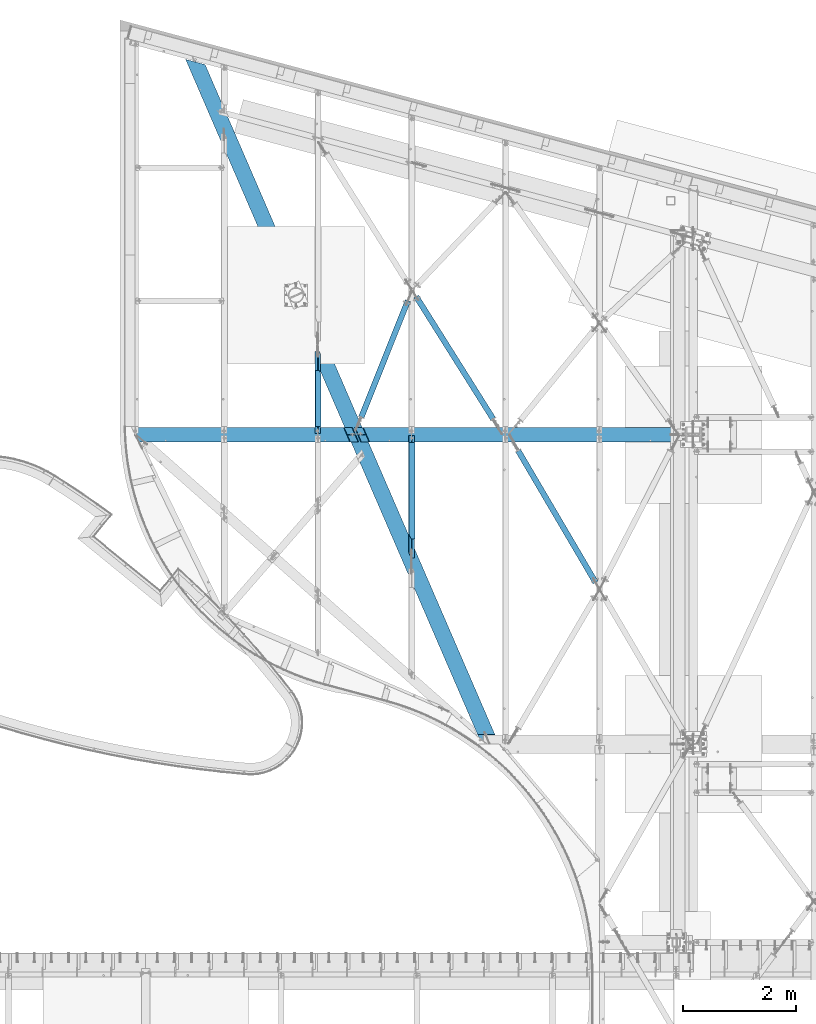
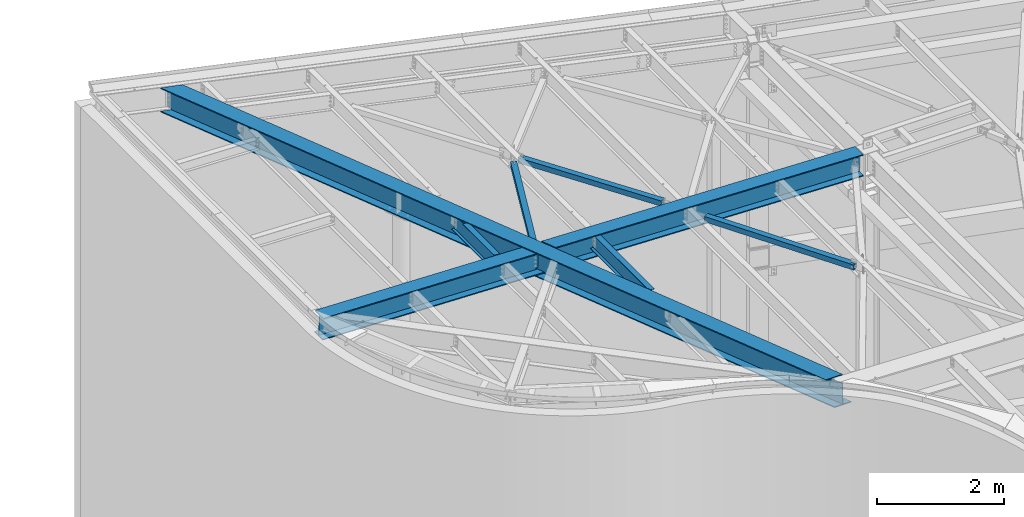
# One storey, part 1155 of 1763: 8 beams, 8 elements without a shape of their own.
"""IFC2X3 building model written with IfcOpenShell, lengths in millimetres."""

import ifcopenshell
import ifcopenshell.guid

model = None  # the IFC model being written
_history = None  # IfcOwnerHistory: only IFC2X3 demands one
_inside = {}  # id of a spatial element -> (the spatial element, [elements in it])
_under = {}  # id of a project, library or spatial element -> (it, [spatial elements below it])
_declared = {}  # id of a project -> (the project, [libraries it declares])
_typed = {}  # id of a type object -> (the type object, [elements of that type])
_made_of = {}  # id of a material, layer set ... -> (it, [elements and type objects made of it])


def new_model(schema):
    """Start an empty IFC model of exactly this schema.

    Asked for "IFC4X3", IfcOpenShell would pick the latest addendum, in which some entities
    have other attributes; the version numbers below select the first issue.
    IFC2X3 requires an IfcOwnerHistory on every rooted entity: one is made here for all.
    """
    global model, _history
    if schema == "IFC4X3":
        model = ifcopenshell.file(schema_version=(4, 3, 0, 0))
    else:
        model = ifcopenshell.file(schema=schema)
    _inside.clear()
    _under.clear()
    _declared.clear()
    _typed.clear()
    _made_of.clear()
    _history = None
    if model.schema == "IFC2X3":
        org = make("IfcOrganization", Name="unknown")
        user = make(
            "IfcPersonAndOrganization",
            ThePerson=make("IfcPerson", FamilyName="unknown"),
            TheOrganization=org,
        )
        app = make(
            "IfcApplication",
            ApplicationDeveloper=org,
            Version="unknown",
            ApplicationFullName="unknown",
            ApplicationIdentifier="unknown",
        )
        _history = make(
            "IfcOwnerHistory",
            OwningUser=user,
            OwningApplication=app,
            ChangeAction="ADDED",
            CreationDate=0,
        )
    return model


def make(cls, **values):
    """One entity of the class cls with the attributes given. An attribute that is None is left unset."""
    return model.create_entity(
        cls, **{name: value for name, value in values.items() if value is not None}
    )


def rooted(cls, **values):
    """An entity with a GlobalId (a new one), such as an element, a storey or a relation."""
    return make(cls, GlobalId=ifcopenshell.guid.new(), OwnerHistory=_history, **values)


def si_unit(unit_type, name, prefix=None):
    """IfcSIUnit, for example si_unit("LENGTHUNIT", "METRE", prefix="MILLI")."""
    return make("IfcSIUnit", UnitType=unit_type, Prefix=prefix, Name=name)


def assignment(units):
    """IfcUnitAssignment: the units of a project."""
    return None if units is None else make("IfcUnitAssignment", Units=units)


def point(xyz):
    """IfcCartesianPoint."""
    return None if xyz is None else make("IfcCartesianPoint", Coordinates=xyz)


def direction(xyz):
    """IfcDirection."""
    return None if xyz is None else make("IfcDirection", DirectionRatios=xyz)


def frame(location, z_axis=None, x_axis=None):
    """IfcAxis2Placement3D, a coordinate frame: its origin and axes. An axis left out is left unset."""
    return make(
        "IfcAxis2Placement3D",
        Location=point(location),
        Axis=direction(z_axis),
        RefDirection=direction(x_axis),
    )


def origin_with_axes():
    """The frame at (0, 0, 0) with the z axis (0, 0, 1) and the x axis (1, 0, 0) written out."""
    return frame((0.0, 0.0, 0.0), z_axis=(0.0, 0.0, 1.0), x_axis=(1.0, 0.0, 0.0))


def place(relative_to, where):
    """IfcLocalPlacement: puts the frame where relative to a parent placement (None: the world)."""
    return make(
        "IfcLocalPlacement", PlacementRelTo=relative_to, RelativePlacement=where
    )


def context(
    kind, dimensions, precision=None, world=None, true_north=None, identifier=None
):
    """IfcGeometricRepresentationContext, for example the 3D "Model" context."""
    return make(
        "IfcGeometricRepresentationContext",
        ContextIdentifier=identifier,
        ContextType=kind,
        CoordinateSpaceDimension=dimensions,
        Precision=precision,
        WorldCoordinateSystem=world,
        TrueNorth=true_north,
    )


def subcontext(parent, identifier, kind, view, scale=None):
    """IfcGeometricRepresentationSubContext, for example "Body" below "Model"."""
    return make(
        "IfcGeometricRepresentationSubContext",
        ContextIdentifier=identifier,
        ContextType=kind,
        ParentContext=parent,
        TargetScale=scale,
        TargetView=view,
    )


def project(units=None, contexts=None):
    """IfcProject with its units and contexts."""
    return rooted(
        "IfcProject",
        Name="project",
        RepresentationContexts=contexts,
        UnitsInContext=assignment(units),
    )


def spatial(cls, under=None, at=None, **own):
    """A site, building, storey or space (cls), placed at a placement, below another one or the project."""
    s = rooted(cls, ObjectPlacement=at, **own)
    if under is not None:
        _under.setdefault(under.id(), (under, []))[1].append(s)
    return s


def faces_of(points, faces, orient=None, outer=None):
    """IfcFace entities. A face is a list of loops; a loop is a list of indices into points, from 0.

    orient and outer hold one flag for each loop. By default every Orientation is true, the
    first loop of a face is its IfcFaceOuterBound and the others are IfcFaceBound.
    """
    made = []
    for i, loops in enumerate(faces):
        bounds = []
        for j, loop in enumerate(loops):
            is_outer = j == 0 if outer is None else outer[i][j]
            bounds.append(
                make(
                    "IfcFaceOuterBound" if is_outer else "IfcFaceBound",
                    Bound=make("IfcPolyLoop", Polygon=[points[k] for k in loop]),
                    Orientation=True if orient is None else orient[i][j],
                )
            )
        made.append(make("IfcFace", Bounds=bounds))
    return made


def faceted_brep(points, faces, orient=None, outer=None, voids=None):
    """IfcFacetedBrep: a solid bounded by flat faces; with voids (closed shells), ...WithVoids."""
    shared = [point(p) for p in points]
    hull = make("IfcClosedShell", CfsFaces=faces_of(shared, faces, orient, outer))
    if voids is None:
        return make("IfcFacetedBrep", Outer=hull)
    return make(
        "IfcFacetedBrepWithVoids",
        Outer=hull,
        Voids=[
            make(cls, CfsFaces=faces_of(shared, fs, o, b)) for cls, fs, o, b in voids
        ],
    )


def shape(context_of_items, identifier, shape_type, items):
    """IfcShapeRepresentation: the items that make up one representation, for example the "Body"."""
    return make(
        "IfcShapeRepresentation",
        ContextOfItems=context_of_items,
        RepresentationIdentifier=identifier,
        RepresentationType=shape_type,
        Items=items,
    )


def material(Name=None, Category=None):
    """IfcMaterial."""
    return make("IfcMaterial", Name=Name, Category=Category)


def made_of(thing, what):
    """Note that an element or type object is made of a material, layer set ...; save() writes the relation."""
    if what is not None:
        _made_of.setdefault(what.id(), (what, []))[1].append(thing)
    return thing


def type_object(cls, material=None, **own):
    """A type object (cls), such as IfcWallType, which elements share."""
    return made_of(rooted(cls, **own), material)


def element(
    cls,
    number,
    at=None,
    inside=None,
    cuts=None,
    type_object=None,
    material=None,
    context=None,
    identifier="Body",
    shape_type=None,
    held_by="IfcProductDefinitionShape",
    body=None,
    shapes=None,
    **own,
):
    """One element of the class cls, such as IfcWall. Its Tag is "e" and its number.

    at: its placement. inside: the storey or other place that contains it. cuts: it is an
    opening in that element (IfcRelVoidsElement). A single representation is given by context,
    identifier, shape_type and body (its items); several are given by shapes. held_by: the class
    of the entity that holds the representations. save() writes the other relations.
    """
    e = rooted(cls, Tag="e%d" % number, ObjectPlacement=at, **own)
    if body is not None:
        shapes = [shape(context, identifier, shape_type, body)]
    if shapes is not None:
        e.Representation = make(held_by, Representations=shapes)
    if inside is not None:
        _inside.setdefault(inside.id(), (inside, []))[1].append(e)
    if cuts is not None:
        rooted(
            "IfcRelVoidsElement", RelatingBuildingElement=cuts, RelatedOpeningElement=e
        )
    if type_object is not None:
        _typed.setdefault(type_object.id(), (type_object, []))[1].append(e)
    return made_of(e, material)


def aggregate(whole, parts):
    """IfcRelAggregates: a whole, such as a stair, and the parts it consists of."""
    return rooted("IfcRelAggregates", RelatingObject=whole, RelatedObjects=parts)


def save(model, path):
    """Write the relations noted so far, then the file.

    IfcRelAggregates (storeys below a building ...), IfcRelContainedInSpatialStructure (elements
    in a storey), IfcRelDefinesByType, IfcRelAssociatesMaterial and IfcRelDeclares: one each for
    every whole, place, type object, material and project.
    """
    for whole, parts in _under.values():
        aggregate(whole, parts)
    for where, things in _inside.values():
        rooted(
            "IfcRelContainedInSpatialStructure",
            RelatedElements=things,
            RelatingStructure=where,
        )
    for kind, things in _typed.values():
        rooted("IfcRelDefinesByType", RelatedObjects=things, RelatingType=kind)
    for what, things in _made_of.values():
        rooted("IfcRelAssociatesMaterial", RelatedObjects=things, RelatingMaterial=what)
    for by, libraries in _declared.values():
        rooted("IfcRelDeclares", RelatingContext=by, RelatedDefinitions=libraries)
    model.write(path)


model = new_model("IFC2X3")

# Units and contexts
model_context = context("Model", 3, precision=1e-05, world=origin_with_axes())
body_context = subcontext(model_context, "Body", "Model", "MODEL_VIEW")
ifc_project = project(units=[si_unit("LENGTHUNIT", "METRE", prefix="MILLI"), si_unit("AREAUNIT", "SQUARE_METRE"), si_unit("VOLUMEUNIT", "CUBIC_METRE"), si_unit("MASSUNIT", "GRAM", prefix="KILO"), si_unit("TIMEUNIT", "SECOND"), si_unit("PLANEANGLEUNIT", "RADIAN"), si_unit("SOLIDANGLEUNIT", "STERADIAN"), si_unit("THERMODYNAMICTEMPERATUREUNIT", "DEGREE_CELSIUS"), si_unit("LUMINOUSINTENSITYUNIT", "LUMEN")], contexts=[model_context])

# Site, building, storey
site_placement = place(None, origin_with_axes())
site = spatial("IfcSite", under=ifc_project, at=site_placement, CompositionType="ELEMENT")
building_placement = place(site_placement, origin_with_axes())
building = spatial("IfcBuilding", under=site, at=building_placement, Name="Undefined", CompositionType="ELEMENT")
storey_placement = place(building_placement, origin_with_axes())
storey = spatial("IfcBuildingStorey", under=building, at=storey_placement, Name="Undefined", CompositionType="ELEMENT", Elevation=0.0)

# Assembly, beam
assembly_1_placement = place(storey_placement, origin_with_axes())
assembly_1 = element("IfcElementAssembly", 1, at=assembly_1_placement, inside=storey, Name="H. BRACE", AssemblyPlace="NOTDEFINED", PredefinedType="RIGID_FRAME")
ifc_material_1 = material()
beam_type_1 = type_object("IfcBeamType", Name="HSS4X4X3/8", PredefinedType="NOTDEFINED")
beam_1_placement = place(assembly_1_placement, frame((-41338.5382217807, 60452.3469434345, 12371.3875), z_axis=(0.0, 0.0, 1.0), x_axis=(-0.50652204411247, 0.862227011191441, 0.0)))
beam_1 = element("IfcBeam", 2, at=beam_1_placement, type_object=beam_type_1, material=ifc_material_1, Name="H. BRACE", ObjectType="HSS4X4X3/8", context=body_context, shape_type="Brep", body=[
    faceted_brep([(142.888415242414, 6.34999999947649, 50.7999999999993), (142.888415242414, 6.34999999947649, 41.2749999999996), (227.099700886218, 6.34999999945467, 41.2749999999996), (227.099700886218, 6.34999999945467, 50.7999999999938), (227.099700886218, -6.35000000040782, 50.7999999999938), (227.099700886218, -6.35000000040782, 41.2749999999996), (142.888415242414, -6.35000000037144, 41.2749999999996), (142.888415242414, -6.35000000037144, 50.7999999999993), (142.888415242414, 6.34999999947649, -41.2749999999996), (142.888415242414, 6.34999999947649, -50.7999999999993), (227.099700886218, 6.34999999945467, -50.8000000000047), (227.099700886218, 6.34999999945467, -41.2749999999996), (227.099700886218, -6.35000000040782, -41.2749999999996), (227.099700886218, -6.35000000040782, -50.8000000000047), (142.888415242414, -6.35000000037144, -50.7999999999993), (142.888415242414, -6.35000000037144, -41.2749999999996), (142.888415242414, -41.2749999998869, -41.2749999999996), (142.888415242414, -41.2749999998869, 41.2749999999996), (2854.96770806139, -41.2750000008291, 41.2749999999996), (2854.9677080754, -41.2750000008291, -41.2749999999996), (142.888415242414, 50.7999999997573, -50.7999999999993), (2854.96770804827, 50.7999999988115, -50.7999999999993), (2854.96770808, -50.8000000007978, -50.7999999999993), (142.888415242414, -50.7999999998519, -50.7999999999993), (142.888415242414, -50.7999999998519, 50.7999999999993), (2854.96770806274, -50.8000000007942, 50.7999999999993), (142.888415242414, 41.2749999997959, 41.2749999999996), (2854.96770803559, 41.27499999885, 41.2749999999996), (142.888415242414, 41.2749999997959, -41.2749999999996), (2854.96770804962, 41.2749999988428, -41.2749999999996), (2854.96770803099, 50.7999999988078, 50.7999999999993), (142.888415242414, 50.7999999997573, 50.7999999999993)], [[[0, 1, 2, 3]], [[4, 5, 6, 7]], [[3, 2, 5, 4]], [[8, 9, 10, 11]], [[12, 13, 14, 15]], [[11, 10, 13, 12]], [[16, 17, 18, 19]], [[9, 20, 21, 22, 23, 14, 13, 10]], [[24, 23, 22, 25]], [[17, 16, 15, 14, 23, 24, 7, 6]], [[1, 26, 27, 18, 17, 6, 5, 2]], [[26, 28, 29, 27]], [[25, 22, 21, 30], [18, 27, 29, 19]], [[20, 31, 30, 21]], [[24, 25, 30, 31, 0, 3, 4, 7]], [[31, 20, 9, 8, 28, 26, 1, 0]], [[16, 19, 29, 28, 8, 11, 12, 15]]]),
])
aggregate(assembly_1, [beam_1])

assembly_2_placement = place(storey_placement, origin_with_axes())
assembly_2 = element("IfcElementAssembly", 3, at=assembly_2_placement, inside=storey, Name="H. BRACE", AssemblyPlace="NOTDEFINED", PredefinedType="RIGID_FRAME")
beam_2_placement = place(assembly_2_placement, frame((-45677.6148262171, 63248.1761413704, 12475.765625), z_axis=(0.0, 0.0, 1.0), x_axis=(0.371159417076474, 0.928569161191266, 0.0)))
beam_2 = element("IfcBeam", 4, at=beam_2_placement, type_object=beam_type_1, material=ifc_material_1, Name="H. BRACE", ObjectType="HSS4X4X3/8", context=body_context, shape_type="Brep", body=[
    faceted_brep([(2510.10293792247, 6.35000001345179, 50.7999999999993), (2425.96543793978, 6.3500000131753, 50.7999999999993), (2425.96543793978, 6.3500000131753, 41.2749999999996), (2510.10293792247, 6.35000001345179, 41.2749999999996), (2425.96543793981, -6.3499999869091, 50.7999999999993), (2425.96543793981, -6.3499999869091, 41.2749999999996), (2510.10293792246, -6.34999998734565, 50.7999999999993), (2510.10293792246, -6.34999998734565, 41.2749999999996), (2510.10293792247, 6.35000001345179, -41.2749999999996), (2425.96543793978, 6.3500000131753, -41.2749999999996), (2425.96543793978, 6.3500000131753, -50.7999999999993), (2510.10293792247, 6.35000001345179, -50.7999999999993), (2425.96543793981, -6.3499999869091, -41.2749999999996), (2425.96543793981, -6.3499999869091, -50.7999999999993), (2510.10293792246, -6.34999998734565, -41.2749999999996), (2510.10293792246, -6.34999998734565, -50.7999999999993), (285.37614554647, 41.2750000009983, 41.2749999999996), (285.376145584705, 41.2750000009983, -41.2749999999996), (2510.10293792247, 41.2750000079832, -41.2749999999996), (2510.10293792247, 41.2750000079832, 41.2749999999996), (2510.10293792247, -41.274999992238, 41.2749999999996), (285.376145562812, -41.2749999992229, 41.2749999999996), (285.376145601054, -41.2749999992229, -41.2749999999996), (2510.10293792247, -41.274999992238, -41.2749999999996), (285.376145607348, -50.7999999992462, -50.7999999999993), (285.376145560287, -50.7999999992462, 50.7999999999993), (285.376145540162, 50.8000000010215, 50.7999999999993), (285.376145587237, 50.8000000010215, -50.7999999999993), (2510.10293792247, 50.8000000080065, 50.7999999999993), (2510.10293792247, 50.8000000080065, -50.7999999999993), (2510.10293792246, -50.7999999922613, -50.7999999999993), (2510.10293792246, -50.7999999922613, 50.7999999999993)], [[[0, 1, 2, 3]], [[4, 5, 2, 1]], [[6, 7, 5, 4]], [[8, 9, 10, 11]], [[12, 13, 10, 9]], [[14, 15, 13, 12]], [[16, 17, 18, 19]], [[20, 21, 16, 19, 3, 2, 5, 7]], [[22, 21, 20, 23]], [[9, 8, 18, 17, 22, 23, 14, 12]], [[24, 25, 26, 27], [16, 21, 22, 17]], [[27, 26, 28, 29]], [[19, 18, 8, 11, 29, 28, 0, 3]], [[30, 24, 27, 29, 11, 10, 13, 15]], [[25, 24, 30, 31]], [[1, 0, 28, 26, 25, 31, 6, 4]], [[31, 30, 15, 14, 23, 20, 7, 6]]]),
])
aggregate(assembly_2, [beam_2])

assembly_3_placement = place(storey_placement, origin_with_axes())
assembly_3 = element("IfcElementAssembly", 5, at=assembly_3_placement, inside=storey, Name="H. BRACE", AssemblyPlace="NOTDEFINED", PredefinedType="RIGID_FRAME")
beam_3_placement = place(assembly_3_placement, frame((-43055.1791956861, 63201.5499998402, 12475.765625), z_axis=(0.0, 0.0, 1.0), x_axis=(-0.532535588045035, 0.84640761307158, 0.0)))
beam_3 = element("IfcBeam", 6, at=beam_3_placement, type_object=beam_type_1, material=ifc_material_1, Name="H. BRACE", ObjectType="HSS4X4X3/8", context=body_context, shape_type="Brep", body=[
    faceted_brep([(2898.33890135751, 6.35000001674643, 50.7999999999993), (2820.76937611714, 6.35000001673916, 50.7999999999993), (2820.76937611714, 6.35000001673916, 41.2749999999996), (2898.33890135751, 6.35000001674643, 41.2749999999996), (2820.76937611714, -6.34999998325065, 50.7999999999993), (2820.76937611714, -6.34999998325065, 41.2749999999996), (2898.33890135751, -6.34999998325793, 50.7999999999993), (2898.33890135751, -6.34999998325793, 41.2749999999996), (2898.33890135751, 6.35000001674643, -41.2749999999996), (2820.76937611714, 6.35000001673916, -41.2749999999996), (2820.76937611714, 6.35000001673916, -50.7999999999993), (2898.33890135751, 6.35000001674643, -50.7999999999993), (2820.76937611714, -6.34999998325065, -41.2749999999996), (2820.76937611714, -6.34999998325065, -50.7999999999993), (2898.33890135751, -6.34999998325793, -41.2749999999996), (2898.33890135751, -6.34999998325793, -50.7999999999993), (333.048359995955, 41.2749999999928, 41.2749999999996), (333.04836002292, 41.2749999999928, -41.2749999999996), (2898.33890135751, 41.2750000000001, -41.2749999999996), (2898.33890135751, 41.2750000000001, 41.2749999999996), (2898.33890135751, -41.274999999981, 41.2749999999996), (333.048360013418, -41.2749999999883, 41.2749999999996), (333.048360040368, -41.2749999999883, -41.2749999999996), (2898.33890135751, -41.274999999981, -41.2749999999996), (333.04836004549, -50.7999999999824, -50.7999999999993), (333.048360012312, -50.7999999999824, 50.7999999999993), (333.048359990818, 50.799999999987, 50.7999999999993), (333.048360024011, 50.799999999987, -50.7999999999993), (2898.33890135751, 50.8000000000015, 50.7999999999993), (2898.33890135751, 50.8000000000015, -50.7999999999993), (2898.33890135751, -50.7999999999824, -50.7999999999993), (2898.33890135751, -50.7999999999824, 50.7999999999993)], [[[0, 1, 2, 3]], [[4, 5, 2, 1]], [[6, 7, 5, 4]], [[8, 9, 10, 11]], [[12, 13, 10, 9]], [[14, 15, 13, 12]], [[16, 17, 18, 19]], [[20, 21, 16, 19, 3, 2, 5, 7]], [[22, 21, 20, 23]], [[9, 8, 18, 17, 22, 23, 14, 12]], [[24, 25, 26, 27], [16, 21, 22, 17]], [[27, 26, 28, 29]], [[19, 18, 8, 11, 29, 28, 0, 3]], [[30, 24, 27, 29, 11, 10, 13, 15]], [[25, 24, 30, 31]], [[1, 0, 28, 26, 25, 31, 6, 4]], [[31, 30, 15, 14, 23, 20, 7, 6]]]),
])
aggregate(assembly_3, [beam_3])

assembly_4_placement = place(storey_placement, origin_with_axes())
assembly_4 = element("IfcElementAssembly", 7, at=assembly_4_placement, inside=storey, Name="BEAM", AssemblyPlace="NOTDEFINED", PredefinedType="RIGID_FRAME")
ifc_material_2 = material(Name="STEEL/A992")
beam_type_2 = type_object("IfcBeamType", Name="W12X16", PredefinedType="NOTDEFINED")
beam_4_placement = place(assembly_4_placement, frame((-44674.7062632819, 60918.8918433085, 12440.7807458876), z_axis=(0.0294363099980619, 0.0, 0.999566657934176), x_axis=(0.0, 1.0, 0.0)))
beam_4 = element("IfcBeam", 8, at=beam_4_placement, type_object=beam_type_2, material=ifc_material_2, Name="BEAM", ObjectType="W12X16", context=body_context, shape_type="Brep", body=[
    faceted_brep([(419.267503132403, -3.17499999983556, 112.419608019094), (419.267503132403, 3.17500000017026, 112.232606414957), (92.0372966428404, 3.17500000017026, 112.232606414957), (92.0372966428404, -3.17499999983556, 112.419608019094), (424.12758265045, -3.17499999983556, 113.386757048042), (424.12758265045, 3.17500000017026, 113.199755443902), (428.247759118603, -3.17499999983556, 116.140964462451), (428.247759118603, 3.17500000017026, 115.953962858312), (431.000773019077, -3.17499999982101, 120.26292715043), (431.000773019077, 3.17500000017753, 120.075925546294), (431.967502941668, -3.17499999981374, 125.125113658423), (431.967502941668, 3.17500000018481, 124.938112054286), (431.967502941668, -50.7999999997846, 152.400000000001), (431.967502941668, 19.0582604178198, 152.40000000002), (431.967502941668, 18.8712588136696, 146.050000000019), (431.967502941668, 3.17500000022119, 146.050000000016), (431.967502941668, -3.17499999978463, 146.050000000014), (431.967502941668, -50.7999999997919, 146.050000000001), (186.143687162039, 50.7999999997701, -152.400000000005), (185.711491960239, 50.7999999997774, -146.050000000007), (2264.40190669086, 50.7999999997774, -146.050000000007), (2264.40190669086, 50.7999999997701, -152.400000000005), (2264.40190669086, -50.800000000243, -146.050000000032), (2264.40190669086, -3.17500000023574, -146.050000000021), (92.0372966428404, -3.17500000023574, -146.050000000021), (92.0372966428404, -50.800000000243, -146.050000000032), (2264.40190669086, -50.8000000002576, -152.400000000034), (92.0372966428404, -50.8000000002576, -152.400000000034), (92.0372965872593, 10.0821818504337, -152.400000000018), (92.0372965886854, 10.2691834513098, -146.050000000017), (2264.40190669086, 3.17499999977008, -146.050000000017), (92.0372966428404, 3.17499999977008, -146.050000000017), (2264.40190669086, 3.17500000017026, 114.040001668231), (2264.40190669086, -3.17499999982829, 114.040001668242), (2226.30190650009, 3.17500000017026, 114.040001668458), (2226.30190650009, -3.17499999982829, 114.040001668443), (2221.44182698205, 3.17500000017026, 114.835632793114), (2221.44182698205, -3.17499999982829, 114.835632793118), (2152.48316260406, 3.17500000017026, 114.835632793258), (2152.48316260406, -3.17499999982829, 114.835632793245), (2147.62308308601, 3.17500000017026, 115.802362715847), (2147.62308308601, -3.17499999982829, 115.802362715833), (2143.50290661786, 3.17500000017753, 118.555376616327), (2143.50290661786, -3.17499999982829, 118.555376616312), (2140.74989271739, 3.17500000018481, 122.67555308448), (2140.74989271739, -3.17499999981374, 122.675553084468), (2139.7831627948, 3.17500000019209, 127.535632602527), (2139.7831627948, -3.17499999980646, 127.535632602516), (2139.7831627948, 50.8000000002357, 152.400000000031), (2139.7831627948, 50.8000000002285, 146.050000000028), (505.760714963304, 50.8000000002285, 146.050000000028), (505.328519752664, 50.8000000002357, 152.400000000031), (2139.7831627948, -50.7999999997846, 152.400000000001), (2139.7831627948, -50.7999999997919, 146.050000000001), (2139.7831627948, -3.17499999978463, 146.050000000014), (2139.7831627948, 3.17500000022119, 146.050000000016)], [[[0, 1, 2, 3]], [[4, 5, 1, 0]], [[6, 7, 5, 4]], [[8, 9, 7, 6]], [[10, 11, 9, 8]], [[12, 13, 14, 15, 11, 10, 16, 17]], [[18, 19, 20, 21]], [[22, 23, 24, 25]], [[26, 22, 25, 27]], [[18, 21, 26, 27, 28]], [[19, 18, 28, 29]], [[30, 20, 19, 29, 31]], [[23, 22, 26, 21, 20, 30, 32, 33]], [[33, 32, 34, 35]], [[35, 34, 36, 37]], [[38, 39, 37, 36]], [[39, 38, 40, 41]], [[41, 40, 42, 43]], [[43, 42, 44, 45]], [[45, 44, 46, 47]], [[48, 49, 50, 51]], [[52, 53, 54, 47, 46, 55, 49, 48]], [[53, 52, 12, 17]], [[54, 53, 17, 16]], [[8, 6, 4, 0, 3, 24, 23, 33, 35, 37, 39, 41, 43, 45, 47, 54, 16, 10]], [[31, 29, 28, 27, 25, 24, 3, 2]], [[55, 46, 44, 42, 40, 38, 36, 34, 32, 30, 31, 2, 1, 5, 7, 9, 11, 15]], [[50, 49, 55, 15, 14]], [[51, 50, 14, 13]], [[52, 48, 51, 13, 12]]]),
])
aggregate(assembly_4, [beam_4])

assembly_5_placement = place(storey_placement, origin_with_axes())
assembly_5 = element("IfcElementAssembly", 9, at=assembly_5_placement, inside=storey, Name="BEAM", AssemblyPlace="NOTDEFINED", PredefinedType="RIGID_FRAME")
beam_5_placement = place(assembly_5_placement, frame((-46340.5472371989, 63201.55, 12489.8609543434), z_axis=(0.0294363099980619, 0.0, 0.999566657934176), x_axis=(0.0, 1.0, 0.0)))
beam_5 = element("IfcBeam", 10, at=beam_5_placement, type_object=beam_type_2, material=ifc_material_2, Name="BEAM", ObjectType="W12X16", context=body_context, shape_type="Brep", body=[
    faceted_brep([(18.2562499854539, 3.17499999977008, -146.050000000016), (18.2562499854539, 50.7999999997701, -146.050000000005), (18.2562499854539, 50.7999999997628, -152.400000000003), (18.2562499854539, -50.8000000002576, -152.400000000032), (18.2562499854539, -50.8000000002503, -146.050000000032), (18.2562499854539, -3.17500000024302, -146.050000000019), (18.2562499988926, -3.17499999983556, 107.996414197045), (18.2562499988926, 3.17500000015571, 107.996414197038), (130.175006293146, -3.17499999983556, 107.996414196812), (130.175006293146, 3.17500000016298, 107.996414196827), (135.035085811192, -3.17499999983556, 108.963144119401), (135.035085811192, 3.17500000016298, 108.963144119414), (139.155262279346, -3.17499999982829, 111.716158019881), (139.155262279346, 3.17500000017026, 111.716158019894), (141.90827617982, -3.17499999982101, 115.836334488036), (141.90827617982, 3.17500000017753, 115.836334488049), (142.875006102411, -3.17499999982101, 120.696414006083), (142.875006102411, 3.17500000018481, 120.696414006095), (142.874993882375, -50.7999999997919, 152.400000000001), (142.874993882375, 50.8000000002285, 152.400000000032), (142.874993882375, 50.8000000002212, 146.05000000003), (142.874993882375, 3.17500000022119, 146.050000000019), (142.874993882375, -3.17499999979191, 146.050000000014), (142.874993882375, -50.7999999997992, 146.050000000001), (1064.18048512434, -50.7999999997919, 146.050000000003), (1063.7482899137, -50.7999999997774, 152.400000000001), (1137.10930630327, 50.800000000243, 152.400000000031), (1137.10930630327, -19.058260599697, 152.400000000012), (1137.10930630327, 50.8000000002285, 146.05000000003), (1137.10930630327, 3.17500000022119, 146.050000000017), (1477.0395126021, 3.17499999977008, -146.050000000016), (1137.10930630327, 3.17500000017026, 117.426500764246), (1138.07603622586, 3.17500000017026, 112.564314256253), (1140.82905012633, 3.17500000016298, 108.442351568272), (1144.94922659449, 3.17500000015571, 105.688144153863), (1149.80930611253, 3.17500000014843, 104.720995124917), (1477.0395126021, 3.17500000014843, 104.720995124917), (1477.0395126021, 50.7999999997846, -146.050000000005), (1477.0395126021, 50.7999999997774, -152.400000000003), (1424.42386185303, -50.8000000002576, -152.400000000032), (1477.03951256677, -28.034335686847, -152.400000000027), (1423.99166665124, -50.8000000002357, -146.050000000032), (1477.03951256819, -27.8473340859782, -146.050000000025), (1477.0395126021, -3.17500000023574, -146.050000000021), (1144.94922659449, -3.17499999984284, 105.875145758), (1140.82905012633, -3.17499999983556, 108.629353172408), (1138.07603622586, -3.17499999982829, 112.751315860391), (1137.10930630327, -3.17499999982101, 117.613502368382), (1137.10930630327, -3.17499999978463, 146.050000000014), (1477.0395126021, -3.17499999984284, 104.907996729053), (1149.80930611253, -3.17499999984284, 104.907996729053), (1137.10930630327, -19.2452622038472, 146.05000000001)], [[[0, 1, 2, 3, 4, 5, 6, 7]], [[8, 9, 7, 6]], [[10, 11, 9, 8]], [[12, 13, 11, 10]], [[14, 15, 13, 12]], [[16, 17, 15, 14]], [[18, 19, 20, 21, 17, 16, 22, 23]], [[18, 23, 24, 25]], [[26, 19, 18, 25, 27]], [[20, 19, 26, 28]], [[21, 20, 28, 29]], [[30, 0, 7, 9, 11, 13, 15, 17, 21, 29, 31, 32, 33, 34, 35, 36]], [[1, 0, 30, 37]], [[2, 1, 37, 38]], [[39, 3, 2, 38, 40]], [[4, 3, 39, 41]], [[5, 4, 41, 42, 43]], [[44, 45, 46, 47, 48, 22, 16, 14, 12, 10, 8, 6, 5, 43, 49, 50]], [[23, 22, 48, 51, 24]], [[27, 25, 24, 51]], [[48, 47, 31, 29, 28, 26, 27, 51]], [[46, 32, 31, 47]], [[45, 33, 32, 46]], [[44, 34, 33, 45]], [[50, 35, 34, 44]], [[49, 36, 35, 50]], [[43, 42, 40, 38, 37, 30, 36, 49]], [[41, 39, 40, 42]]]),
])
aggregate(assembly_5, [beam_5])

assembly_6_placement = place(storey_placement, origin_with_axes())
assembly_6 = element("IfcElementAssembly", 11, at=assembly_6_placement, inside=storey, Name="BEAM", AssemblyPlace="NOTDEFINED", PredefinedType="RIGID_FRAME")
beam_type_3 = type_object("IfcBeamType", Name="W16X77", PredefinedType="NOTDEFINED")
beam_6_placement = place(assembly_6_placement, frame((-45663.5890366639, 63201.5500000137, 12420.9685247061), z_axis=(0.0307997289940758, 0.0, 0.999525575807789), x_axis=(0.999525575807789, 0.0, -0.0307997289940772)))
beam_6 = element("IfcBeam", 12, at=beam_6_placement, type_object=beam_type_3, material=ifc_material_2, Name="BEAM", ObjectType="W16X77", context=body_context, shape_type="Brep", body=[
    faceted_brep([(204.625998440351, -5.55625000000146, 152.143278683869), (199.817766600288, 5.55625000000146, 152.142870531523), (17.9196580551143, 5.55625000000146, 152.108225655904), (22.7278898925651, -5.55625000000146, 152.108633808275), (210.300759519785, -5.55625000000146, 153.693819866707), (205.492527679708, 5.55625000000146, 153.693411714363), (214.128280453129, -5.55625000000146, 157.839824109173), (209.320048613059, 5.55625000000146, 157.839415956829), (214.862809046055, -5.55625000000146, 163.231881709071), (210.054577205985, 5.55625000000146, 163.231473556723), (212.265276558675, -5.55625000000146, 168.115027062271), (207.457044718605, 5.55625000000146, 168.114618909925), (187.325439452565, -5.55625000000146, 190.241785832706), (182.517207612502, 5.55625000000146, 190.241377680362), (166.568662949197, -5.55625000000146, 190.240023874074), (161.760431109135, 5.55625000000146, 190.239615721728), (232.631830981736, -130.175000000003, 209.549999999846), (119.987842236485, 130.175000000003, 209.549999999901), (108.006195037597, 130.175000000003, 190.499999999913), (161.924201845541, 5.55625000000146, 190.499999999884), (166.732176974911, -5.55625000000146, 190.499999999884), (220.650183782855, -130.175000000003, 190.499999999856), (22.729258539126, -5.55625000000146, 135.985316982933), (17.9210267016824, 5.55625000000146, 135.984908747272), (26.8172090465087, 5.55625000000146, -152.717248164201), (31.6254408865716, -5.55625000000146, -152.716840011857), (66.6260876020824, 5.55625000000146, -152.668447349335), (71.4343194421454, -5.55625000000146, -152.668039196991), (72.4959835151967, 5.55625000000146, -154.337718851591), (77.3042153552597, -5.55625000000146, -154.337310699248), (76.3081416135974, 5.55625000000146, -158.761251037276), (81.1163734536603, -5.55625000000146, -158.760842884931), (76.7260013838459, 5.55625000000146, -164.388132769796), (81.5342332239161, -5.55625000000146, -164.387724617449), (73.6030592301759, 5.55625000000146, -169.245552916111), (78.4112910702461, -5.55625000000146, -169.245144763765), (49.7390334734664, 5.55625000000146, -190.499999999989), (54.5472653070465, -5.55625000000146, -190.499999999991), (40.9661755616762, 5.55625000000146, -190.499999999984), (45.7744073952708, -5.55625000000146, -190.499999999985), (99.6952929575782, -130.174996499569, -190.404695995403), (-12.9547100006239, 130.175000000003, -190.499999999958), (-25.1677329471495, 130.175000000003, -209.549999999948), (87.4761671239467, -130.175000000003, -209.550000000003), (5834.21246241718, -130.175000000003, 190.499999997079), (5833.62544908647, -130.175000000003, 209.549999997074), (5834.21246241718, -5.55625000000146, 190.499999997079), (5845.95272903116, 5.55625000000146, -190.500000002856), (5834.21246241718, 5.55625000000146, 190.499999997079), (5834.21246241718, 130.175000000003, 190.499999997079), (5833.62544908647, 130.175000000003, 209.549999997074), (5845.95272903116, -5.55625000000146, -190.500000002856), (5845.95272903116, -130.175000000003, -190.500000002856), (5846.53974236186, -130.175000000003, -209.550000002853), (5846.53974236186, 130.175000000003, -209.550000002853), (5845.95272903116, 130.175000000003, -190.500000002856), (108.468150869354, -130.175000000003, -190.500000000016), (-4.18185208884825, 130.175000000003, -190.499999999962)], [[[0, 1, 2, 3]], [[4, 5, 1, 0]], [[6, 7, 5, 4]], [[8, 9, 7, 6]], [[10, 11, 9, 8]], [[12, 13, 11, 10]], [[14, 15, 13, 12]], [[16, 17, 18, 19, 15, 14, 20, 21]], [[22, 23, 24, 25]], [[25, 24, 26, 27]], [[27, 26, 28, 29]], [[29, 28, 30, 31]], [[31, 30, 32, 33]], [[33, 32, 34, 35]], [[35, 34, 36, 37]], [[37, 36, 38, 39]], [[40, 39, 38, 41, 42, 43]], [[44, 45, 16, 21]], [[46, 44, 21, 20]], [[47, 48, 49, 50, 45, 44, 46, 51, 52, 53, 54, 55]], [[53, 52, 56, 40, 43]], [[54, 53, 43, 42]], [[57, 55, 54, 42, 41]], [[36, 47, 55, 57, 41, 38]], [[23, 22, 3, 2]], [[13, 15, 19, 48, 47, 36, 34, 32, 30, 28, 26, 24, 23, 2, 1, 5, 7, 9, 11]], [[49, 48, 19, 18]], [[50, 49, 18, 17]], [[45, 50, 17, 16]], [[4, 0, 3, 22, 25, 27, 29, 31, 33, 35, 37, 51, 46, 20, 14, 12, 10, 8, 6]], [[56, 52, 51, 37, 39, 40]]]),
])
aggregate(assembly_6, [beam_6])

assembly_7_placement = place(storey_placement, origin_with_axes())
assembly_7 = element("IfcElementAssembly", 13, at=assembly_7_placement, inside=storey, Name="BEAM", AssemblyPlace="NOTDEFINED", PredefinedType="RIGID_FRAME")
beam_7_placement = place(assembly_7_placement, frame((-49661.1499636879, 63201.5499999989, 12530.5210107236), z_axis=(0.0294363099980619, 0.0, 0.999566657934176), x_axis=(0.999566657934176, 0.0, -0.02943630999806)))
beam_7 = element("IfcBeam", 14, at=beam_7_placement, type_object=beam_type_3, material=ifc_material_2, Name="BEAM", ObjectType="W16X77", context=body_context, shape_type="Brep", body=[
    faceted_brep([(3837.86955278747, -5.55625000000146, 189.706250023661), (3811.27399832992, -5.55625000000146, 189.706250019117), (3806.46585776868, 5.55625000000146, 189.706250008025), (3833.0614122303, 5.55625000000146, 189.70625001267), (3796.09587121051, -5.55625000000146, 184.492059413073), (3791.28773064927, 5.55625000000146, 184.49205940198), (3791.38338732396, -5.55625000000146, 181.227280889669), (3786.57524676272, 5.55625000000146, 181.227280878576), (3789.37370335632, -5.55625000000146, 176.131945455911), (3784.56556279508, 5.55625000000146, 176.131945444817), (3790.71727667993, -5.55625000000146, 170.855217134995), (3785.90913611869, 5.55625000000146, 170.855217123901), (3794.97924430753, -5.55625000000146, 167.104969848109), (3790.17110374628, 5.55625000000146, 167.104969837015), (3800.8956348776, -5.55625000000146, 164.306250398102), (3796.08749431637, 5.55625000000146, 164.30625038701), (3982.2373513953, -5.55625000000146, 164.306250449401), (3977.4292108382, 5.55625000000146, 164.306250438258), (-2.9831426218152e-10, 130.175000000003, 190.499999999956), (-3.34694050252438e-10, 130.175000000003, 209.549999999952), (3766.3838135329, 130.175000000003, 209.549999999152), (3779.11817512831, 130.175000000003, 190.499999999154), (-2.9831426218152e-10, -130.175000000003, 190.499999999956), (-2.9831426218152e-10, -5.55625000000146, 190.499999999956), (3837.84617765199, -5.55625000000146, 190.499999999141), (3891.76603961817, -130.175000000003, 190.499999999131), (-3.34694050252438e-10, -130.175000000003, 209.549999999952), (3879.03167834232, -130.175000000003, 209.549999999128), (3833.03803709449, 5.55625000000146, 190.499999999143), (-2.9831426218152e-10, 5.55625000000146, 190.499999999956), (3.20142135024071e-10, -130.175000000003, -209.549999999952), (2.83762346953154e-10, -130.175000000003, -190.499999999958), (2.83762346953154e-10, -5.55625000000146, -190.499999999958), (2.83762346953154e-10, 5.55625000000146, -190.499999999958), (2.83762346953154e-10, 130.175000000003, -190.499999999958), (3.20142135024071e-10, 130.175000000003, -209.549999999952), (3911.42215294495, 130.175000000003, -190.500000000788), (3925.25997351202, 130.175000000003, -190.500000000791), (3937.97975594351, 130.175000000003, -209.550000000791), (4050.64470401081, -130.167608302087, -209.544469608625), (4024.07001763589, -130.175000000003, -190.500000000811), (4037.90783820298, -130.175000000003, -190.500000000815), (3970.15015557345, -5.55625000000146, -190.5000000008), (3983.98797614054, -5.55625000000146, -190.500000000804), (3979.17983557446, 5.55625000000146, -190.500000000804), (3965.34201500738, 5.55625000000146, -190.500000000799), (3949.69688909613, 5.55625000000146, -184.76499992453), (3954.5050296622, -5.55625000000146, -184.76499991713), (3945.16489046266, 5.55625000000146, -181.536704259892), (3949.97303102874, -5.55625000000146, -181.53670425249), (3943.19394820368, 5.55625000000146, -176.592003422817), (3948.00208876976, -5.55625000000146, -176.592003415413), (3944.38630337117, 5.55625000000146, -171.44180003887), (3949.19444393724, -5.55625000000146, -171.441800031469), (3948.37761995927, 5.55625000000146, -167.659790085107), (3953.18576052535, -5.55625000000146, -167.659790077705), (3953.2339258323, 5.55625000000146, -165.100000174041), (3958.04206639838, -5.55625000000146, -165.10000016664), (3987.12989244042, 5.55625000000146, -165.100001311028), (3991.93803299763, -5.55625000000146, -165.100001303597)], [[[0, 1, 2, 3]], [[4, 5, 2, 1]], [[6, 7, 5, 4]], [[8, 9, 7, 6]], [[10, 11, 9, 8]], [[12, 13, 11, 10]], [[14, 15, 13, 12]], [[16, 17, 15, 14]], [[18, 19, 20, 21]], [[22, 23, 24, 25]], [[26, 22, 25, 27]], [[19, 26, 27, 20]], [[25, 24, 28, 21, 20, 27]], [[29, 18, 21, 28]], [[30, 31, 32, 23, 22, 26, 19, 18, 29, 33, 34, 35]], [[35, 34, 36, 37, 38]], [[30, 35, 38, 39]], [[40, 31, 30, 39, 41]], [[42, 32, 31, 40, 41, 43]], [[39, 38, 37, 44, 43, 41]], [[36, 34, 33, 45, 44, 37]], [[43, 44, 45, 42]], [[42, 45, 46, 47]], [[47, 46, 48, 49]], [[49, 48, 50, 51]], [[51, 50, 52, 53]], [[53, 52, 54, 55]], [[55, 54, 56, 57]], [[57, 56, 58, 59]], [[12, 10, 8, 6, 4, 1, 0, 24, 23, 32, 42, 47, 49, 51, 53, 55, 57, 59, 16, 14]], [[28, 24, 0, 3]], [[58, 56, 54, 52, 50, 48, 46, 45, 33, 29, 28, 3, 2, 5, 7, 9, 11, 13, 15, 17]], [[59, 58, 17, 16]]]),
])
aggregate(assembly_7, [beam_7])

assembly_8_placement = place(storey_placement, origin_with_axes())
assembly_8 = element("IfcElementAssembly", 15, at=assembly_8_placement, inside=storey, Name="BEAM", AssemblyPlace="NOTDEFINED", PredefinedType="RIGID_FRAME")
beam_type_4 = type_object("IfcBeamType", Name="W18X86", PredefinedType="NOTDEFINED")
beam_8_placement = place(assembly_8_placement, frame((-43280.2868913122, 57705.1069135829, 12318.5086258351), z_axis=(0.00492406207071326, -0.0113853491635018, 0.999923060758751), x_axis=(-0.396925948816292, 0.917766810575233, 0.0124045379942588)))
beam_8 = element("IfcBeam", 16, at=beam_8_placement, type_object=beam_type_4, material=ifc_material_2, Name="BEAM", ObjectType="W18X86", context=body_context, shape_type="Brep", body=[
    faceted_brep([(13286.9364279688, -6.35000002472589, -182.954132709232), (13210.8231694911, -6.35000002459128, -182.954132688172), (13220.8855280818, 6.34999997544946, -182.95413269002), (13286.9364279117, 6.34999997532213, -182.954132708337), (13204.6589108575, -6.35000002458401, -183.909083498516), (13214.7212694483, 6.34999997545674, -183.909083500364), (13199.4216701565, -6.35000002455854, -186.630324741451), (13209.4840287473, 6.34999997547493, -186.630324743299), (13195.8990548425, -6.35000002454763, -190.708619948688), (13205.9614134332, 6.34999997548221, -190.708619950534), (13194.6208167902, -6.35000002455126, -195.530650792951), (13204.6831753809, 6.34999997548948, -195.530650794799), (13311.3627371489, 141.287499975879, -214.312499998785), (13204.45017712, 6.3499999755004, -214.312499998734), (13194.3878185291, -6.3500000245258, -214.31249999873), (13087.4752585003, -141.287500024893, -214.312499998681), (13087.2389336981, -141.287500024879, -233.362499998686), (13311.1264123467, 141.287499975893, -233.36249999879), (-44.4135882749397, -141.287500000279, -233.362500000027), (-44.1772636453388, -141.287500000308, -214.31250000002), (14.1864904138638, -6.34999999984211, -214.312500000073), (13.950165790855, -6.34999998458079, -233.362500000083), (19.6795495946135, -6.3499999998603, -214.312500000075), (19.4432249632227, -6.34999998502099, -233.362500000081), (130.654778923999, -141.287500001057, 214.312500000153), (189.018533015784, -6.35000000059517, 214.312500000098), (13199.7051218191, -6.35000002495872, 214.312500001426), (13092.7925617903, -141.287500025319, 214.312500001475), (13225.8810959216, 6.34999997506748, 194.335941062356), (13215.8187373308, -6.35000002496963, 194.335941064202), (13291.6168970687, -6.35000002510787, 194.335941044028), (13291.6168970779, 6.34999997495106, 194.335941044883), (13219.6440612441, 6.34999997508567, 195.314519380823), (13209.5817026533, -6.3500000249478, 195.314519382671), (13214.3681961717, 6.3499999750893, 198.099448736322), (13204.3058375809, -6.35000002494053, 198.09944873817), (13210.8665475137, 6.3499999750893, 202.261552511212), (13200.804188923, -6.35000002494417, 202.261552513059), (13209.6787432232, 6.3499999750893, 207.159422112185), (13199.6163846324, -6.35000002495144, 207.159422114031), (253.111667642574, 141.287499999893, 233.362500000045), (130.891100250359, -141.287500001068, 233.362500000159), (13093.0288857045, -141.287500025341, 233.362500001482), (13316.9163643531, 141.287499975431, 233.362500001378), (252.875346316214, 141.287499999908, 214.312500000038), (13316.6800404389, 141.287499975446, 214.31250000137), (194.511592224415, 6.34999999945285, 214.312500000093), (13209.7674804101, 6.34999997507839, 214.312500001421), (194.288535319894, 6.34999999946376, 196.331752771001), (188.795476111263, -6.35000000058062, 196.331752772025), (193.190468452245, 6.34999999947468, 191.51625227369), (187.697409243614, -6.35000000056971, 191.516252274714), (190.180799470865, 6.34999999948923, 187.44511241824), (184.687740262234, -6.35000000055516, 187.445112419262), (185.711189141293, 6.34999999949287, 184.729288813121), (180.218129932662, -6.35000000054424, 184.729288814144), (180.452391501851, 6.34999999950742, 183.77634487352), (174.95933229322, -6.3500000005406, 183.776344874543), (24.6180377460551, 6.34999999980209, 183.77634489447), (24.6180377594574, -6.3500000002532, 183.776344894706), (19.6795496194391, 6.350000000195, -214.31250000008), (19.4432249654201, 6.34999994372629, -233.362500000087), (78.0433036786562, 141.287500000653, -214.312500000135), (77.8069790490554, 141.287500000672, -233.362500000143)], [[[0, 1, 2, 3]], [[2, 1, 4, 5]], [[5, 4, 6, 7]], [[7, 6, 8, 9]], [[9, 8, 10, 11]], [[12, 13, 11, 10, 14, 15, 16, 17]], [[18, 19, 20, 21]], [[22, 23, 21, 20]], [[24, 25, 26, 27]], [[28, 29, 30, 31]], [[32, 33, 29, 28]], [[34, 35, 33, 32]], [[36, 37, 35, 34]], [[38, 39, 37, 36]], [[40, 41, 42, 43]], [[44, 40, 43, 45]], [[46, 44, 45, 47]], [[43, 42, 27, 26, 39, 38, 47, 45]], [[41, 24, 27, 42]], [[40, 44, 46, 48, 49, 25, 24, 41]], [[50, 51, 49, 48]], [[52, 53, 51, 50]], [[54, 55, 53, 52]], [[56, 57, 55, 54]], [[58, 59, 57, 56]], [[60, 61, 23, 22, 59, 58]], [[62, 63, 61, 60]], [[63, 62, 12, 17]], [[18, 21, 23, 61, 63, 17, 16]], [[19, 18, 16, 15]], [[22, 20, 19, 15, 14]], [[30, 29, 33, 35, 37, 39, 26, 25, 49, 51, 53, 55, 57, 59, 22, 14, 10, 8, 6, 4, 1, 0]], [[31, 30, 0, 3]], [[5, 7, 9, 11, 13, 60, 58, 56, 54, 52, 50, 48, 46, 47, 38, 36, 34, 32, 28, 31, 3, 2]], [[62, 60, 13, 12]]]),
])
aggregate(assembly_8, [beam_8])

save(model, "model.ifc")
